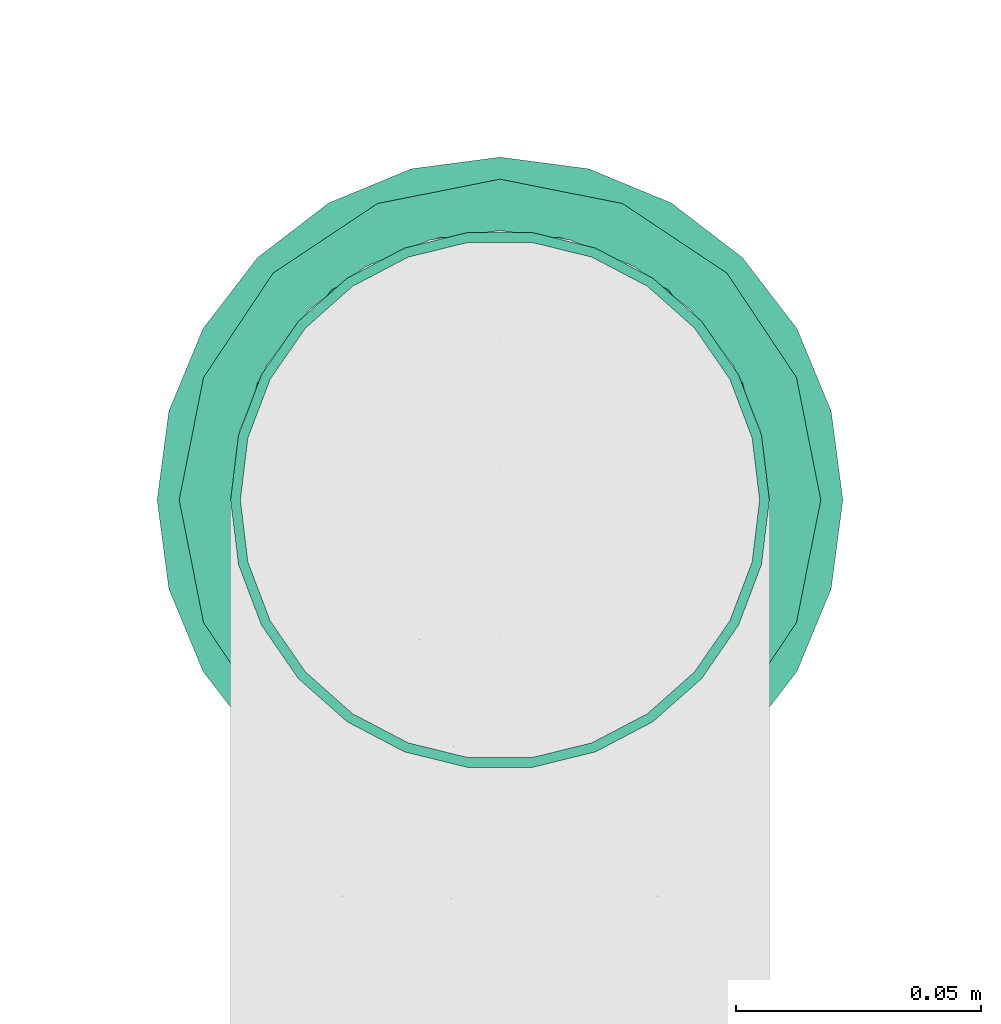
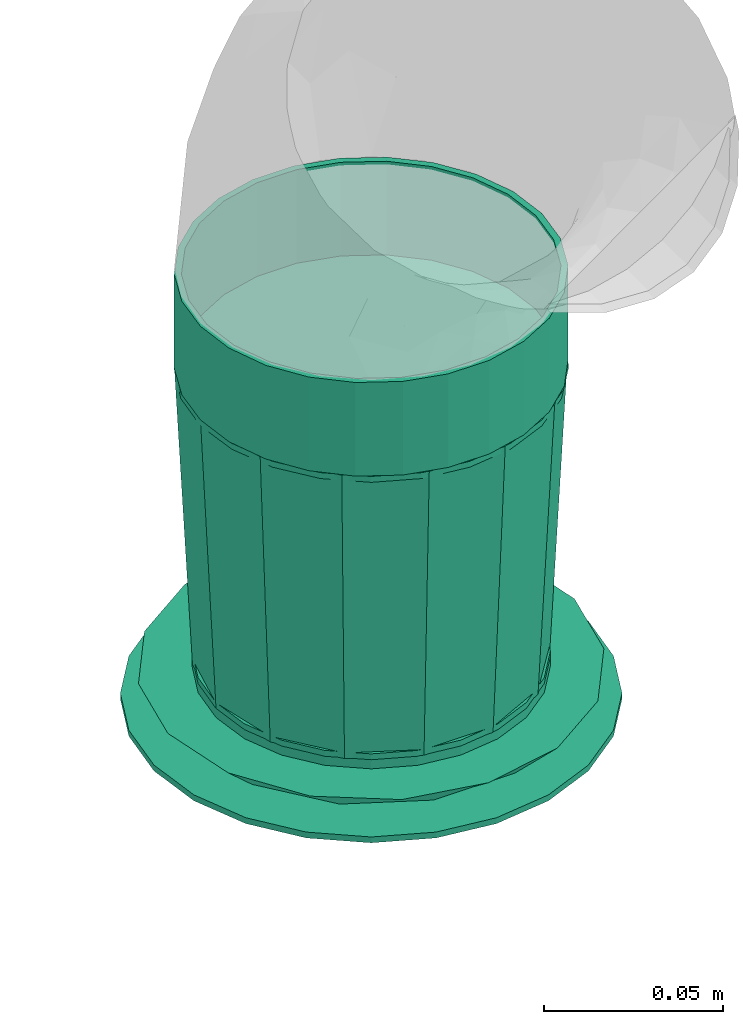
# One storey, part 42 of 123: 1 flow fitting, 1 flow segment, 1 flow terminal.
"""IFC2X3 building model written with IfcOpenShell, lengths in millimetres."""

import ifcopenshell
import ifcopenshell.guid

model = None  # the IFC model being written
_history = None  # IfcOwnerHistory: only IFC2X3 demands one
_inside = {}  # id of a spatial element -> (the spatial element, [elements in it])
_under = {}  # id of a project, library or spatial element -> (it, [spatial elements below it])
_declared = {}  # id of a project -> (the project, [libraries it declares])
_typed = {}  # id of a type object -> (the type object, [elements of that type])
_made_of = {}  # id of a material, layer set ... -> (it, [elements and type objects made of it])


def new_model(schema):
    """Start an empty IFC model of exactly this schema.

    Asked for "IFC4X3", IfcOpenShell would pick the latest addendum, in which some entities
    have other attributes; the version numbers below select the first issue.
    IFC2X3 requires an IfcOwnerHistory on every rooted entity: one is made here for all.
    """
    global model, _history
    if schema == "IFC4X3":
        model = ifcopenshell.file(schema_version=(4, 3, 0, 0))
    else:
        model = ifcopenshell.file(schema=schema)
    _inside.clear()
    _under.clear()
    _declared.clear()
    _typed.clear()
    _made_of.clear()
    _history = None
    if model.schema == "IFC2X3":
        org = make("IfcOrganization", Name="unknown")
        user = make(
            "IfcPersonAndOrganization",
            ThePerson=make("IfcPerson", FamilyName="unknown"),
            TheOrganization=org,
        )
        app = make(
            "IfcApplication",
            ApplicationDeveloper=org,
            Version="unknown",
            ApplicationFullName="unknown",
            ApplicationIdentifier="unknown",
        )
        _history = make(
            "IfcOwnerHistory",
            OwningUser=user,
            OwningApplication=app,
            ChangeAction="ADDED",
            CreationDate=0,
        )
    return model


def make(cls, **values):
    """One entity of the class cls with the attributes given. An attribute that is None is left unset."""
    return model.create_entity(
        cls, **{name: value for name, value in values.items() if value is not None}
    )


def entity(cls, *values):
    """Any entity or typed value of the class cls, its attributes in the order of the schema. None: left unset."""
    e = model.create_entity(cls)
    for i, value in enumerate(values):
        if value is not None:
            e[i] = value
    return e


def rooted(cls, **values):
    """An entity with a GlobalId (a new one), such as an element, a storey or a relation."""
    return make(cls, GlobalId=ifcopenshell.guid.new(), OwnerHistory=_history, **values)


def si_unit(unit_type, name, prefix=None):
    """IfcSIUnit, for example si_unit("LENGTHUNIT", "METRE", prefix="MILLI")."""
    return make("IfcSIUnit", UnitType=unit_type, Prefix=prefix, Name=name)


def converted_unit(unit_type, name, factor, base, dimensions=None, offset=None):
    """IfcConversionBasedUnit, such as the inch: factor (a typed value) times the base unit."""
    return make(
        "IfcConversionBasedUnit"
        if offset is None
        else "IfcConversionBasedUnitWithOffset",
        ConversionOffset=offset,
        Dimensions=None
        if dimensions is None
        else entity("IfcDimensionalExponents", *dimensions),
        UnitType=unit_type,
        Name=name,
        ConversionFactor=make(
            "IfcMeasureWithUnit", ValueComponent=factor, UnitComponent=base
        ),
    )


def derived_unit(unit_type, elements):
    """IfcDerivedUnit: a product of units, each with its exponent."""
    return make(
        "IfcDerivedUnit",
        Elements=[
            make("IfcDerivedUnitElement", Unit=unit, Exponent=power)
            for unit, power in elements
        ],
        UnitType=unit_type,
    )


def assignment(units):
    """IfcUnitAssignment: the units of a project."""
    return None if units is None else make("IfcUnitAssignment", Units=units)


def point(xyz):
    """IfcCartesianPoint."""
    return None if xyz is None else make("IfcCartesianPoint", Coordinates=xyz)


def direction(xyz):
    """IfcDirection."""
    return None if xyz is None else make("IfcDirection", DirectionRatios=xyz)


def frame(location, z_axis=None, x_axis=None):
    """IfcAxis2Placement3D, a coordinate frame: its origin and axes. An axis left out is left unset."""
    return make(
        "IfcAxis2Placement3D",
        Location=point(location),
        Axis=direction(z_axis),
        RefDirection=direction(x_axis),
    )


def frame_2d(location, x_axis=None):
    """IfcAxis2Placement2D, a coordinate frame in the plane: its origin and x axis."""
    return make(
        "IfcAxis2Placement2D", Location=point(location), RefDirection=direction(x_axis)
    )


def origin_with_axes():
    """The frame at (0, 0, 0) with the z axis (0, 0, 1) and the x axis (1, 0, 0) written out."""
    return frame((0.0, 0.0, 0.0), z_axis=(0.0, 0.0, 1.0), x_axis=(1.0, 0.0, 0.0))


def origin_2d_with_axis():
    """The frame at (0, 0) in the plane with the x axis (1, 0) written out."""
    return frame_2d((0.0, 0.0), x_axis=(1.0, 0.0))


def place(relative_to, where):
    """IfcLocalPlacement: puts the frame where relative to a parent placement (None: the world)."""
    return make(
        "IfcLocalPlacement", PlacementRelTo=relative_to, RelativePlacement=where
    )


def context(
    kind, dimensions, precision=None, world=None, true_north=None, identifier=None
):
    """IfcGeometricRepresentationContext, for example the 3D "Model" context."""
    return make(
        "IfcGeometricRepresentationContext",
        ContextIdentifier=identifier,
        ContextType=kind,
        CoordinateSpaceDimension=dimensions,
        Precision=precision,
        WorldCoordinateSystem=world,
        TrueNorth=true_north,
    )


def subcontext(parent, identifier, kind, view, scale=None):
    """IfcGeometricRepresentationSubContext, for example "Body" below "Model"."""
    return make(
        "IfcGeometricRepresentationSubContext",
        ContextIdentifier=identifier,
        ContextType=kind,
        ParentContext=parent,
        TargetScale=scale,
        TargetView=view,
    )


def project(units=None, contexts=None):
    """IfcProject with its units and contexts."""
    return rooted(
        "IfcProject",
        Name="project",
        RepresentationContexts=contexts,
        UnitsInContext=assignment(units),
    )


def spatial(cls, under=None, at=None, **own):
    """A site, building, storey or space (cls), placed at a placement, below another one or the project."""
    s = rooted(cls, ObjectPlacement=at, **own)
    if under is not None:
        _under.setdefault(under.id(), (under, []))[1].append(s)
    return s


def profile(cls, at=None, kind="AREA", **sizes):
    """A parametric profile (cls). Its sizes go by their IFC names, for example OverallWidth=200.0."""
    return make(cls, ProfileType=kind, Position=at, **sizes)


def hollow_circle(**sizes):
    """IfcCircleHollowProfileDef."""
    return profile("IfcCircleHollowProfileDef", **sizes)


def extrude(swept, where, along, depth):
    """IfcExtrudedAreaSolid: the profile swept, set in the frame where, extruded along a direction by depth."""
    return make(
        "IfcExtrudedAreaSolid",
        SweptArea=swept,
        Position=where,
        ExtrudedDirection=direction(along),
        Depth=depth,
    )


def faces_of(points, faces, orient=None, outer=None):
    """IfcFace entities. A face is a list of loops; a loop is a list of indices into points, from 0.

    orient and outer hold one flag for each loop. By default every Orientation is true, the
    first loop of a face is its IfcFaceOuterBound and the others are IfcFaceBound.
    """
    made = []
    for i, loops in enumerate(faces):
        bounds = []
        for j, loop in enumerate(loops):
            is_outer = j == 0 if outer is None else outer[i][j]
            bounds.append(
                make(
                    "IfcFaceOuterBound" if is_outer else "IfcFaceBound",
                    Bound=make("IfcPolyLoop", Polygon=[points[k] for k in loop]),
                    Orientation=True if orient is None else orient[i][j],
                )
            )
        made.append(make("IfcFace", Bounds=bounds))
    return made


def open_shell(faces, orient=None, outer=None):
    """The faces of one IfcOpenShell. surface_model builds it on its shared points."""
    return ("IfcOpenShell", faces, orient, outer)


def surface_model(cls, points, shells):
    """IfcFaceBasedSurfaceModel or IfcShellBasedSurfaceModel (cls): surfaces that need not close."""
    shared = [point(p) for p in points]
    made = [make(c, CfsFaces=faces_of(shared, fs, o, b)) for c, fs, o, b in shells]
    if cls == "IfcFaceBasedSurfaceModel":
        return make(cls, FbsmFaces=made)
    return make(cls, SbsmBoundary=made)


def shape(context_of_items, identifier, shape_type, items):
    """IfcShapeRepresentation: the items that make up one representation, for example the "Body"."""
    return make(
        "IfcShapeRepresentation",
        ContextOfItems=context_of_items,
        RepresentationIdentifier=identifier,
        RepresentationType=shape_type,
        Items=items,
    )


def source(mapping_origin, context_of_items, identifier, shape_type, items):
    """IfcRepresentationMap: a shape defined once, which mapped items show again and again."""
    return make(
        "IfcRepresentationMap",
        MappingOrigin=mapping_origin,
        MappedRepresentation=shape(context_of_items, identifier, shape_type, items),
    )


def transform(
    local_origin,
    x_axis=None,
    y_axis=None,
    z_axis=None,
    scale=None,
    scale2=None,
    scale3=None,
    uniform=True,
):
    """IfcCartesianTransformationOperator3D, or its non-uniform kind. x_axis, y_axis, z_axis: its Axis1, 2, 3."""
    if uniform:
        return make(
            "IfcCartesianTransformationOperator3D",
            Axis1=direction(x_axis),
            Axis2=direction(y_axis),
            LocalOrigin=point(local_origin),
            Scale=scale,
            Axis3=direction(z_axis),
        )
    return make(
        "IfcCartesianTransformationOperator3DnonUniform",
        Axis1=direction(x_axis),
        Axis2=direction(y_axis),
        LocalOrigin=point(local_origin),
        Scale=scale,
        Axis3=direction(z_axis),
        Scale2=scale2,
        Scale3=scale3,
    )


def mapped(mapping_source, mapping_target):
    """IfcMappedItem: shows the shape of a source again, moved by a transform."""
    return make(
        "IfcMappedItem", MappingSource=mapping_source, MappingTarget=mapping_target
    )


def material(Name=None, Category=None):
    """IfcMaterial."""
    return make("IfcMaterial", Name=Name, Category=Category)


def layer(
    of_material, thickness, ventilated=None, Name=None, Category=None, Priority=None
):
    """IfcMaterialLayer: one layer of a wall or slab, of a material (None: an air gap)."""
    return make(
        "IfcMaterialLayer",
        Material=of_material,
        LayerThickness=thickness,
        IsVentilated=ventilated,
        Name=Name,
        Category=Category,
        Priority=Priority,
    )


def layer_set(layers, Name=None):
    """IfcMaterialLayerSet."""
    return make("IfcMaterialLayerSet", MaterialLayers=layers, LayerSetName=Name)


def layer_usage(for_layer_set, set_direction, sense, offset, extent=None):
    """IfcMaterialLayerSetUsage: how a layer set lies in its element."""
    return make(
        "IfcMaterialLayerSetUsage",
        ForLayerSet=for_layer_set,
        LayerSetDirection=set_direction,
        DirectionSense=sense,
        OffsetFromReferenceLine=offset,
        ReferenceExtent=extent,
    )


def made_of(thing, what):
    """Note that an element or type object is made of a material, layer set ...; save() writes the relation."""
    if what is not None:
        _made_of.setdefault(what.id(), (what, []))[1].append(thing)
    return thing


def type_object(cls, material=None, **own):
    """A type object (cls), such as IfcWallType, which elements share."""
    return made_of(rooted(cls, **own), material)


def element(
    cls,
    number,
    at=None,
    inside=None,
    cuts=None,
    type_object=None,
    material=None,
    context=None,
    identifier="Body",
    shape_type=None,
    held_by="IfcProductDefinitionShape",
    body=None,
    shapes=None,
    **own,
):
    """One element of the class cls, such as IfcWall. Its Tag is "e" and its number.

    at: its placement. inside: the storey or other place that contains it. cuts: it is an
    opening in that element (IfcRelVoidsElement). A single representation is given by context,
    identifier, shape_type and body (its items); several are given by shapes. held_by: the class
    of the entity that holds the representations. save() writes the other relations.
    """
    e = rooted(cls, Tag="e%d" % number, ObjectPlacement=at, **own)
    if body is not None:
        shapes = [shape(context, identifier, shape_type, body)]
    if shapes is not None:
        e.Representation = make(held_by, Representations=shapes)
    if inside is not None:
        _inside.setdefault(inside.id(), (inside, []))[1].append(e)
    if cuts is not None:
        rooted(
            "IfcRelVoidsElement", RelatingBuildingElement=cuts, RelatedOpeningElement=e
        )
    if type_object is not None:
        _typed.setdefault(type_object.id(), (type_object, []))[1].append(e)
    return made_of(e, material)


def aggregate(whole, parts):
    """IfcRelAggregates: a whole, such as a stair, and the parts it consists of."""
    return rooted("IfcRelAggregates", RelatingObject=whole, RelatedObjects=parts)


def save(model, path):
    """Write the relations noted so far, then the file.

    IfcRelAggregates (storeys below a building ...), IfcRelContainedInSpatialStructure (elements
    in a storey), IfcRelDefinesByType, IfcRelAssociatesMaterial and IfcRelDeclares: one each for
    every whole, place, type object, material and project.
    """
    for whole, parts in _under.values():
        aggregate(whole, parts)
    for where, things in _inside.values():
        rooted(
            "IfcRelContainedInSpatialStructure",
            RelatedElements=things,
            RelatingStructure=where,
        )
    for kind, things in _typed.values():
        rooted("IfcRelDefinesByType", RelatedObjects=things, RelatingType=kind)
    for what, things in _made_of.values():
        rooted("IfcRelAssociatesMaterial", RelatedObjects=things, RelatingMaterial=what)
    for by, libraries in _declared.values():
        rooted("IfcRelDeclares", RelatingContext=by, RelatedDefinitions=libraries)
    model.write(path)


model = new_model("IFC2X3")

# Units and contexts
model_context = context("Model", 3, precision=1e-05, world=origin_with_axes(), true_north=direction((0.0, 1.0)))
body_context = subcontext(model_context, "Body", "Model", "MODEL_VIEW")
ifc_project = project(units=[si_unit("AREAUNIT", "SQUARE_METRE"), si_unit("VOLUMEUNIT", "CUBIC_METRE", prefix="DECI"), si_unit("TIMEUNIT", "SECOND"), si_unit("THERMODYNAMICTEMPERATUREUNIT", "DEGREE_CELSIUS"), si_unit("PRESSUREUNIT", "PASCAL"), si_unit("MASSUNIT", "GRAM", prefix="KILO"), si_unit("LENGTHUNIT", "METRE", prefix="MILLI"), si_unit("POWERUNIT", "WATT"), si_unit("ELECTRICCURRENTUNIT", "AMPERE"), si_unit("ELECTRICVOLTAGEUNIT", "VOLT"), derived_unit("VOLUMETRICFLOWRATEUNIT", [(si_unit("VOLUMEUNIT", "CUBIC_METRE", prefix="DECI"), 1), (si_unit("TIMEUNIT", "SECOND"), -1)]), derived_unit("LINEARVELOCITYUNIT", [(si_unit("LENGTHUNIT", "METRE"), 1), (si_unit("TIMEUNIT", "SECOND"), -1)]), derived_unit("MASSDENSITYUNIT", [(si_unit("MASSUNIT", "GRAM", prefix="KILO"), 1), (si_unit("VOLUMEUNIT", "CUBIC_METRE"), -1)]), converted_unit("PLANEANGLEUNIT", "DEGREE", entity("IfcRatioMeasure", 0.01745), si_unit("PLANEANGLEUNIT", "RADIAN"), dimensions=[0, 0, 0, 0, 0, 0, 0])], contexts=[model_context])

# Site, building, storey
site_placement = place(None, origin_with_axes())
site = spatial("IfcSite", under=ifc_project, at=site_placement, CompositionType="ELEMENT")
building_placement = place(site_placement, origin_with_axes())
building = spatial("IfcBuilding", under=site, at=building_placement, Name="mc-building", CompositionType="ELEMENT")
storey_placement = place(building_placement, origin_with_axes())
storey = spatial("IfcBuildingStorey", under=building, at=storey_placement, Name="1. Korrus", CompositionType="ELEMENT", Elevation=0.0)

# Flow terminal
air_terminal_type = type_object("IfcAirTerminalType", Name="100", PredefinedType="NOTDEFINED")
shared_shape_1 = source(origin_with_axes(), body_context, "Body", "SurfaceModel", [
    surface_model("IfcShellBasedSurfaceModel", [(11.2, -70.0, 0.0), (11.2, -67.61481, -18.11733), (11.2, -67.61481, 18.11733), (6.2, -14.64625, -20.15883), (9.2, -22.36867, -22.36867), (6.2, -21.19625, -15.39997), (9.2, 16.375, -28.36233), (6.2, 8.09625, -24.91768), (6.2, 14.64625, -20.15883), (6.2, -8.09625, -24.91768), (9.2, -16.375, -28.36233), (6.2, 21.19625, -15.39997), (9.2, 22.36867, -22.36867), (9.2, -8.1875, -30.55617), (9.2, 8.1875, -30.55617), (9.2, 28.36233, -16.375), (9.2, -28.36233, -16.375), (6.2, 14.64625, 20.15883), (9.2, 22.36867, 22.36867), (6.2, 21.19625, 15.39997), (9.2, -16.375, 28.36233), (6.2, -8.09625, 24.91768), (6.2, -14.64625, 20.15883), (6.2, 8.09625, 24.91768), (9.2, 16.375, 28.36233), (6.2, -21.19625, 15.39997), (9.2, -22.36867, 22.36867), (9.2, 8.1875, 30.55617), (9.2, -8.1875, 30.55617), (9.2, -28.36233, 16.375), (9.2, 28.36233, 16.375), (6.2, -53.11211, -25.57744), (6.2, -36.75472, -46.08897), (6.2, -13.11761, -57.472), (6.2, 13.11761, -57.472), (6.2, 36.75472, -46.08897), (6.2, 53.11211, -25.57744), (0.0, -12.53288, -63.00706), (6.2, 0.0, -57.472), (0.0, -46.3155, -46.3155), (0.0, -35.69063, -53.4148), (0.0, 0.0, -65.5), (6.2, 44.93342, -35.83321), (0.0, 46.3155, -46.3155), (0.0, 35.69063, -53.4148), (6.2, -44.93342, -35.83321), (0.0, 12.53288, -63.00706), (0.0, 25.06576, -60.51411), (6.2, 56.03105, -12.78872), (0.0, 60.51411, -25.06576), (0.0, 63.00706, -12.53288), (0.0, 53.4148, -35.69063), (0.0, -25.06576, -60.51411), (0.0, -63.00706, -12.53288), (0.0, -60.51411, -25.06576), (6.2, -56.03105, -12.78872), (0.0, -53.4148, -35.69063), (6.2, 13.11761, 57.472), (0.0, 12.53288, 63.00706), (6.2, 0.0, 57.472), (6.2, 36.75472, 46.08897), (0.0, 46.3155, 46.3155), (0.0, 35.69063, 53.4148), (0.0, 0.0, 65.5), (6.2, -44.93342, 35.83321), (6.2, -36.75472, 46.08897), (0.0, -46.3155, 46.3155), (0.0, -35.69063, 53.4148), (6.2, 44.93342, 35.83321), (0.0, -12.53288, 63.00706), (0.0, -25.06576, 60.51411), (6.2, -13.11761, 57.472), (6.2, -56.03105, 12.78872), (0.0, -60.51411, 25.06576), (0.0, -63.00706, 12.53288), (0.0, -53.4148, 35.69063), (0.0, 25.06576, 60.51411), (0.0, 63.00706, 12.53288), (0.0, 60.51411, 25.06576), (6.2, 56.03105, 12.78872), (0.0, 53.4148, 35.69063), (-3.1, 43.30127, 25.0), (-3.1, -48.29629, -12.94095), (-3.1, -43.30127, 25.0), (-3.1, 25.0, -43.30127), (-3.1, 48.29629, -12.94095), (-3.1, 35.35534, -35.35534), (-3.1, -35.35534, -35.35534), (-3.1, -25.0, -43.30127), (-43.1, 43.46666, 11.64686), (-3.1, 38.97115, 22.5), (-3.1, 43.46666, 11.64686), (-3.1, 45.0, 0.0), (-43.1, 45.0, 0.0), (-3.1, 31.81981, 31.81981), (-43.1, 38.97115, 22.5), (-43.1, -38.97115, 22.5), (-3.1, -38.97115, 22.5), (-3.1, -31.81981, 31.81981), (-3.1, -43.46666, 11.64686), (-43.1, -43.46666, 11.64686), (-43.1, -45.0, 0.0), (-3.1, -45.0, 0.0), (-43.1, -43.46666, -11.64686), (-3.1, -38.97115, -22.5), (-3.1, -43.46666, -11.64686), (-3.1, -11.64686, -43.46666), (-3.1, -22.5, -38.97115), (-43.1, -22.5, -38.97115), (-3.1, -31.81981, -31.81981), (-43.1, -38.97115, -22.5), (-43.1, 22.5, -38.97115), (-3.1, 22.5, -38.97115), (-3.1, 11.64686, -43.46666), (-43.1, 38.97115, -22.5), (-3.1, 38.97115, -22.5), (-3.1, 31.81981, -31.81981), (-3.1, 43.46666, -11.64686), (-43.1, 43.46666, -11.64686), (11.2, -49.49747, -49.49747), (11.2, -35.0, -60.62178), (11.2, -18.11733, -67.61481), (11.2, 67.61481, 18.11733), (11.2, -60.62178, -35.0), (11.2, 18.11733, -67.61481), (11.2, 35.0, -60.62178), (11.2, 0.0, -70.0), (11.2, 60.62178, -35.0), (11.2, 67.61481, -18.11733), (11.2, 49.49747, -49.49747), (11.2, -49.49747, 49.49747), (11.2, -60.62178, 35.0), (11.2, -35.0, 60.62178), (11.2, -18.11733, 67.61481), (11.2, 0.0, 70.0), (11.2, 60.62178, 35.0), (11.2, 49.49747, 49.49747), (11.2, 70.0, 0.0), (11.2, 35.0, 60.62178), (11.2, 18.11733, 67.61481), (9.2, -49.49747, 49.49747), (9.2, -35.0, 60.62178), (9.2, -18.11733, 67.61481), (9.2, -67.61481, 18.11733), (9.2, -70.0, 0.0), (9.2, -60.62178, 35.0), (9.2, 67.61481, 18.11733), (9.2, 35.0, 60.62178), (9.2, 18.11733, 67.61481), (9.2, 0.0, 70.0), (9.2, 60.62178, 35.0), (9.2, 49.49747, 49.49747), (9.2, -67.61481, -18.11733), (9.2, -49.49747, -49.49747), (9.2, -60.62178, -35.0), (9.2, -18.11733, -67.61481), (9.2, 70.0, 0.0), (9.2, -35.0, -60.62178), (9.2, 0.0, -70.0), (9.2, 60.62178, -35.0), (9.2, 49.49747, -49.49747), (9.2, 67.61481, -18.11733), (9.2, 35.0, -60.62178), (9.2, 18.11733, -67.61481), (9.2, -32.75, 0.0), (9.2, 0.0, 32.75), (9.2, 32.75, 0.0), (9.2, 0.0, -32.75), (6.2, 26.2, 0.0), (6.2, -26.2, 0.0), (9.2, -31.06579, -6.28555), (6.2, -23.69812, -7.69999), (6.2, 23.69812, -7.69999), (9.2, 31.06579, -6.28555), (6.2, 0.0, -24.91768), (9.2, 31.06579, 6.28555), (6.2, 23.69812, 7.69999), (6.2, -23.69812, 7.69999), (9.2, -31.06579, 6.28555), (6.2, 0.0, 24.91768), (6.2, 53.11211, 25.57744), (6.2, 58.95, 0.0), (6.2, -53.11211, 25.57744), (6.2, -58.95, 0.0), (0.0, 65.5, 0.0), (0.0, -65.5, 0.0), (6.2, -24.93616, -51.78048), (6.2, 24.93616, -51.78048), (6.2, 24.93616, 51.78048), (6.2, -24.93616, 51.78048), (-3.1, 0.0, 50.0), (-3.1, 35.35534, 35.35534), (-3.1, -12.94095, 48.29629), (-3.1, -25.0, 43.30127), (-3.1, -35.35534, 35.35534), (-3.1, 25.0, 43.30127), (-3.1, 12.94095, 48.29629), (-3.1, 48.29629, 12.94095), (-3.1, 50.0, 0.0), (-3.1, -50.0, 0.0), (-3.1, -48.29629, 12.94095), (-3.1, -43.30127, -25.0), (-3.1, -12.94095, -48.29629), (-3.1, 0.0, -50.0), (-3.1, 43.30127, -25.0), (-3.1, 12.94095, -48.29629), (0.0, -12.94095, -48.29629), (0.0, 0.0, -50.0), (0.0, -25.0, -43.30127), (0.0, -35.35534, -35.35534), (0.0, -48.29629, -12.94095), (0.0, 25.0, -43.30127), (0.0, -43.30127, -25.0), (0.0, 43.30127, 25.0), (0.0, 12.94095, -48.29629), (0.0, 43.30127, -25.0), (0.0, 48.29629, -12.94095), (0.0, 35.35534, -35.35534), (0.0, 50.0, 0.0), (0.0, -50.0, 0.0), (0.0, -48.29629, 12.94095), (0.0, -43.30127, 25.0), (0.0, -35.35534, 35.35534), (0.0, -12.94095, 48.29629), (0.0, -25.0, 43.30127), (0.0, 35.35534, 35.35534), (0.0, 0.0, 50.0), (0.0, 48.29629, 12.94095), (0.0, 25.0, 43.30127), (0.0, 12.94095, 48.29629), (-43.1, -22.5, 38.97115), (-43.1, -11.64686, 43.46666), (-43.1, 0.0, 45.0), (-43.1, 11.64686, 43.46666), (-43.1, -31.81981, 31.81981), (-43.1, 31.81981, 31.81981), (-43.1, 22.5, 38.97115), (-43.1, -31.81981, -31.81981), (-43.1, 31.81981, -31.81981), (-43.1, -11.64686, -43.46666), (-43.1, 11.64686, -43.46666), (-43.1, 0.0, -45.0), (-3.1, 0.0, -45.0), (-3.1, 0.0, 45.0), (-3.1, -22.5, 38.97115), (-3.1, -11.64686, 43.46666), (-3.1, 11.64686, 43.46666), (-3.1, 22.5, 38.97115)], [open_shell([[[0, 1, 2]], [[3, 4, 5]], [[6, 7, 8]], [[3, 9, 10]], [[4, 3, 10]], [[11, 12, 8]], [[13, 10, 9]], [[7, 6, 14]], [[6, 8, 12]], [[12, 11, 15]], [[16, 5, 4]], [[17, 18, 19]], [[20, 21, 22]], [[17, 23, 24]], [[18, 17, 24]], [[25, 26, 22]], [[27, 24, 23]], [[21, 20, 28]], [[20, 22, 26]], [[26, 25, 29]], [[30, 19, 18]], [[31, 32, 33]], [[34, 35, 36]], [[33, 37, 38]], [[32, 39, 40]], [[41, 38, 37]], [[42, 35, 43]], [[44, 43, 35]], [[39, 32, 45]], [[46, 47, 34]], [[48, 49, 50]], [[38, 46, 34]], [[42, 43, 51]], [[33, 52, 37]], [[53, 54, 55]], [[46, 38, 41]], [[56, 39, 45]], [[57, 58, 59]], [[60, 61, 62]], [[63, 59, 58]], [[64, 65, 66]], [[67, 66, 65]], [[61, 60, 68]], [[69, 70, 71]], [[72, 73, 74]], [[59, 69, 71]], [[64, 66, 75]], [[57, 76, 58]], [[77, 78, 79]], [[69, 59, 63]], [[80, 61, 68]], [[81, 82, 83]], [[84, 85, 86]], [[87, 82, 88]], [[89, 90, 91]], [[91, 92, 93]], [[94, 90, 95]], [[96, 97, 98]], [[99, 97, 100]], [[101, 102, 99]], [[103, 104, 105]], [[105, 102, 101]], [[106, 107, 108]], [[109, 104, 110]], [[111, 112, 113]], [[114, 115, 116]], [[117, 115, 118]], [[93, 92, 117]], [[119, 120, 121]], [[1, 119, 121]], [[122, 1, 121]], [[123, 119, 1]], [[124, 122, 121]], [[125, 122, 124]], [[121, 126, 124]], [[127, 128, 129]], [[129, 128, 122]], [[129, 122, 125]], [[130, 131, 2]], [[132, 130, 2]], [[122, 133, 2]], [[132, 2, 133]], [[134, 133, 122]], [[135, 136, 122]], [[122, 128, 137]], [[136, 138, 122]], [[139, 122, 138]], [[122, 139, 134]], [[2, 1, 122]], [[140, 141, 142]], [[143, 140, 142]], [[142, 144, 143]], [[145, 140, 143]], [[146, 144, 142]], [[147, 146, 148]], [[149, 148, 146]], [[150, 146, 151]], [[147, 151, 146]], [[146, 142, 149]], [[146, 152, 144]], [[153, 154, 152]], [[155, 153, 152]], [[146, 156, 155]], [[157, 153, 155]], [[158, 155, 156]], [[159, 160, 161]], [[156, 161, 160]], [[160, 162, 156]], [[163, 156, 162]], [[163, 158, 156]], [[152, 146, 155]], [[156, 128, 161]], [[161, 127, 159]], [[162, 160, 125]], [[129, 160, 159]], [[163, 162, 124]], [[128, 127, 161]], [[156, 137, 128]], [[162, 125, 124]], [[125, 160, 129]], [[159, 127, 129]], [[163, 124, 126]], [[126, 158, 163]], [[158, 121, 155]], [[155, 120, 157]], [[154, 153, 123]], [[119, 153, 157]], [[152, 154, 1]], [[120, 119, 157]], [[155, 121, 120]], [[152, 1, 0]], [[1, 154, 123]], [[153, 119, 123]], [[152, 0, 144]], [[126, 121, 158]], [[144, 2, 143]], [[143, 131, 145]], [[141, 140, 132]], [[130, 140, 145]], [[142, 141, 133]], [[2, 131, 143]], [[144, 0, 2]], [[141, 132, 133]], [[132, 140, 130]], [[145, 131, 130]], [[142, 133, 134]], [[134, 149, 142]], [[149, 139, 148]], [[148, 138, 147]], [[150, 151, 135]], [[136, 151, 147]], [[146, 150, 122]], [[138, 136, 147]], [[148, 139, 138]], [[146, 122, 137]], [[122, 150, 135]], [[151, 136, 135]], [[146, 137, 156]], [[134, 139, 149]], [[30, 24, 164]], [[24, 20, 164]], [[165, 20, 24]], [[164, 20, 29]], [[166, 30, 16]], [[16, 6, 166]], [[167, 6, 10]], [[30, 164, 16]], [[10, 6, 16]], [[6, 15, 166]], [[21, 19, 11]], [[23, 19, 21]], [[11, 19, 168]], [[7, 25, 21]], [[7, 5, 169]], [[21, 11, 7]], [[9, 5, 7]], [[169, 25, 7]], [[170, 164, 169]], [[170, 171, 16]], [[11, 172, 15]], [[172, 168, 173]], [[174, 13, 9]], [[166, 173, 168]], [[172, 173, 15]], [[169, 171, 170]], [[5, 16, 171]], [[167, 174, 14]], [[174, 167, 13]], [[14, 174, 7]], [[175, 166, 168]], [[175, 176, 30]], [[25, 177, 29]], [[177, 169, 178]], [[179, 27, 23]], [[164, 178, 169]], [[177, 178, 29]], [[168, 176, 175]], [[19, 30, 176]], [[165, 179, 28]], [[179, 165, 27]], [[28, 179, 21]], [[180, 60, 57]], [[181, 180, 65]], [[65, 57, 71]], [[180, 57, 65]], [[65, 182, 181]], [[182, 36, 181]], [[183, 34, 36]], [[31, 34, 183]], [[31, 33, 34]], [[182, 183, 36]], [[70, 63, 49]], [[70, 73, 66]], [[49, 63, 184]], [[78, 76, 61]], [[76, 78, 184]], [[184, 63, 76]], [[73, 70, 49]], [[39, 54, 185]], [[41, 39, 185]], [[52, 39, 41]], [[43, 185, 49]], [[185, 43, 47]], [[185, 47, 41]], [[73, 49, 185]], [[55, 54, 31]], [[31, 54, 56]], [[52, 186, 40]], [[53, 55, 183]], [[56, 45, 31]], [[185, 53, 183]], [[32, 40, 186]], [[33, 186, 52]], [[44, 35, 187]], [[49, 36, 51]], [[34, 47, 187]], [[42, 51, 36]], [[187, 47, 44]], [[49, 48, 36]], [[48, 50, 181]], [[184, 181, 50]], [[79, 78, 180]], [[180, 78, 80]], [[76, 188, 62]], [[77, 79, 181]], [[80, 68, 180]], [[184, 77, 181]], [[60, 62, 188]], [[57, 188, 76]], [[67, 65, 189]], [[73, 182, 75]], [[71, 70, 189]], [[64, 75, 182]], [[189, 70, 67]], [[73, 72, 182]], [[72, 74, 183]], [[185, 183, 74]], [[190, 191, 192]], [[193, 192, 194]], [[83, 192, 81]], [[194, 192, 83]], [[195, 191, 196]], [[191, 190, 196]], [[197, 198, 81]], [[81, 192, 191]], [[198, 84, 81]], [[199, 200, 83]], [[81, 88, 82]], [[201, 82, 87]], [[88, 81, 202]], [[81, 203, 202]], [[204, 86, 85]], [[205, 203, 84]], [[84, 198, 85]], [[81, 84, 203]], [[199, 83, 82]], [[206, 207, 208]], [[209, 208, 210]], [[210, 208, 211]], [[212, 209, 210]], [[210, 211, 213]], [[214, 211, 207]], [[211, 208, 207]], [[215, 216, 217]], [[211, 217, 216]], [[216, 218, 211]], [[219, 210, 220]], [[221, 210, 213]], [[222, 221, 223]], [[213, 223, 221]], [[224, 222, 223]], [[223, 225, 226]], [[227, 213, 218]], [[218, 213, 211]], [[228, 229, 225]], [[223, 213, 225]], [[226, 225, 229]], [[221, 220, 210]], [[199, 220, 200]], [[200, 221, 83]], [[193, 194, 224]], [[222, 194, 83]], [[192, 193, 223]], [[220, 221, 200]], [[199, 219, 220]], [[193, 224, 223]], [[224, 194, 222]], [[83, 221, 222]], [[192, 223, 226]], [[226, 190, 192]], [[190, 229, 196]], [[196, 228, 195]], [[81, 191, 213]], [[225, 191, 195]], [[197, 81, 227]], [[228, 225, 195]], [[196, 229, 228]], [[197, 227, 218]], [[227, 81, 213]], [[191, 225, 213]], [[197, 218, 198]], [[226, 229, 190]], [[198, 216, 85]], [[85, 215, 204]], [[84, 86, 211]], [[217, 86, 204]], [[205, 84, 214]], [[216, 215, 85]], [[198, 218, 216]], [[84, 211, 214]], [[211, 86, 217]], [[204, 215, 217]], [[205, 214, 207]], [[207, 203, 205]], [[203, 206, 202]], [[202, 208, 88]], [[201, 87, 212]], [[209, 87, 88]], [[82, 201, 210]], [[208, 209, 88]], [[202, 206, 208]], [[82, 210, 219]], [[210, 201, 212]], [[87, 209, 212]], [[82, 219, 199]], [[207, 206, 203]], [[230, 231, 232]], [[230, 232, 233]], [[230, 100, 96]], [[234, 230, 96]], [[100, 230, 233]], [[235, 89, 236]], [[100, 233, 236]], [[95, 89, 235]], [[118, 89, 93]], [[118, 236, 89]], [[118, 100, 236]], [[110, 103, 101]], [[237, 110, 101]], [[238, 108, 101]], [[237, 101, 108]], [[239, 108, 238]], [[114, 238, 118]], [[238, 101, 118]], [[240, 241, 111]], [[238, 111, 241]], [[238, 241, 239]], [[100, 118, 101]], [[106, 242, 107]], [[107, 112, 109]], [[102, 105, 104]], [[112, 104, 109]], [[92, 104, 117]], [[113, 112, 242]], [[112, 107, 242]], [[115, 117, 116]], [[112, 116, 117]], [[112, 117, 104]], [[92, 102, 104]], [[97, 99, 243]], [[98, 97, 244]], [[243, 245, 244]], [[97, 243, 244]], [[246, 243, 99]], [[90, 94, 91]], [[92, 91, 247]], [[94, 247, 91]], [[247, 99, 92]], [[247, 246, 99]], [[102, 92, 99]], [[101, 99, 100]], [[100, 97, 96]], [[230, 234, 244]], [[98, 234, 96]], [[231, 230, 245]], [[245, 230, 244]], [[244, 234, 98]], [[245, 243, 231]], [[243, 232, 231]], [[236, 233, 246]], [[236, 247, 235]], [[89, 95, 90]], [[94, 95, 235]], [[93, 89, 91]], [[232, 246, 233]], [[246, 247, 236]], [[243, 246, 232]], [[247, 94, 235]], [[93, 117, 118]], [[118, 115, 114]], [[111, 238, 112]], [[116, 238, 114]], [[240, 111, 113]], [[112, 238, 116]], [[240, 113, 242]], [[242, 241, 240]], [[108, 239, 106]], [[108, 107, 237]], [[103, 110, 104]], [[109, 110, 237]], [[101, 103, 105]], [[241, 106, 239]], [[242, 106, 241]], [[107, 109, 237]]])]),
])
flow_terminal_placement = place(storey_placement, frame((15517.82156, 4715.81442, 2200.0), z_axis=(0.0, -1.0, 0.0), x_axis=(0.0, 0.0, -1.0)))
element("IfcFlowTerminal", 1, at=flow_terminal_placement, inside=storey, type_object=air_terminal_type, Name="100", context=body_context, shape_type="MappedRepresentation", body=[
    mapped(shared_shape_1, transform((0.0, 0.0, 0.0), scale=1.0)),
])

# Flow fitting
duct_fitting_type = type_object("IfcDuctFittingType", PredefinedType="TRANSITION")
shared_shape_2 = source(origin_with_axes(), body_context, "Body", "SurfaceModel", [
    surface_model("IfcShellBasedSurfaceModel", [(100.0, -55.0, 0.0), (100.0, -12.23865, 53.62104), (100.0, -34.29194, 43.00073), (100.0, 49.55329, 23.86361), (100.0, 34.29194, 43.00073), (100.0, 49.55329, -23.86361), (0.0, -45.04844, -21.69419), (0.0, -50.0, 0.0), (0.0, -45.04844, 21.69419), (0.0, 31.17449, 39.09157), (0.0, 45.04844, 21.69419), (0.0, 50.0, 0.0), (98.0, 47.63139, 27.5), (98.0, 0.0, 55.0), (98.0, 38.89087, 38.89087), (98.0, -38.89087, 38.89087), (98.0, -47.63139, 27.5), (100.0, 12.23865, 53.62104), (100.0, -49.55329, 23.86361), (100.0, 55.0, 0.0), (100.0, 12.23865, -53.62104), (100.0, 34.29194, -43.00073), (100.0, -49.55329, -23.86361), (100.0, -34.29194, -43.00073), (100.0, -12.23865, -53.62104), (0.0, -31.17449, 39.09157), (0.0, -11.12605, 48.7464), (0.0, 11.12605, 48.7464), (0.0, -31.17449, -39.09157), (0.0, 11.12605, -48.7464), (0.0, -11.12605, -48.7464), (0.0, 45.04844, -21.69419), (0.0, 31.17449, -39.09157), (0.0, 47.52422, -10.84709), (0.0, 38.11147, -30.39288), (100.0, 41.92261, -33.43217), (100.0, -41.92261, -33.43217), (0.0, -38.11147, -30.39288), (100.0, 23.2653, -48.31088), (0.0, 21.15027, -43.91899), (100.0, 52.32388, -11.72483), (0.0, 0.0, -48.7464), (100.0, 0.0, -53.62104), (0.0, -21.15027, -43.91899), (100.0, -23.2653, -48.31088), (0.0, -47.52422, -10.84709), (100.0, -52.32388, -11.72483), (0.0, -47.52422, 10.84709), (0.0, -38.11147, 30.39288), (100.0, -41.92261, 33.43217), (100.0, 41.92261, 33.43217), (0.0, 38.11147, 30.39288), (100.0, -23.2653, 48.31088), (0.0, -21.15027, 43.91899), (100.0, -52.32388, 11.72483), (0.0, 0.0, 48.7464), (100.0, 0.0, 53.62104), (0.0, 21.15027, 43.91899), (100.0, 23.2653, 48.31088), (0.0, 47.52422, 10.84709), (100.0, 52.32388, 11.72483), (100.0, -14.23505, -53.12592), (100.0, 0.0, -55.0), (100.0, -27.5, -47.63139), (100.0, 27.5, -47.63139), (100.0, -38.89087, -38.89087), (100.0, -53.12592, -14.23505), (100.0, -47.63139, -27.5), (100.0, -47.63139, 27.5), (100.0, 14.23505, -53.12592), (100.0, 38.89087, -38.89087), (100.0, 47.63139, -27.5), (100.0, 47.63139, 27.5), (100.0, 53.12592, -14.23505), (100.0, -53.12592, 14.23505), (100.0, -38.89087, 38.89087), (100.0, -27.5, 47.63139), (100.0, 0.0, 55.0), (100.0, -14.23505, 53.12592), (100.0, 53.12592, 14.23505), (100.0, 38.89087, 38.89087), (100.0, 27.5, 47.63139), (100.0, 14.23505, 53.12592), (98.0, -27.5, 47.63139), (98.0, -14.23505, 53.12592), (98.0, -53.12592, -14.23505), (98.0, 14.23505, 53.12592), (98.0, 27.5, 47.63139), (98.0, 53.12592, 14.23505), (98.0, 55.0, 0.0), (98.0, -47.63139, -27.5), (98.0, -53.12592, 14.23505), (98.0, 27.5, -47.63139), (98.0, -27.5, -47.63139), (98.0, -38.89087, -38.89087), (98.0, 0.0, -55.0), (98.0, -14.23505, -53.12592), (98.0, 38.89087, -38.89087), (98.0, 47.63139, -27.5), (98.0, 53.12592, -14.23505), (98.0, 14.23505, -53.12592), (98.0, -55.0, 0.0), (0.0, 0.0, 50.0), (0.0, 35.35534, 35.35534), (0.0, -12.94095, 48.29629), (0.0, -25.0, 43.30127), (0.0, -35.35534, 35.35534), (0.0, -48.29629, 12.94095), (0.0, -43.30127, 25.0), (0.0, 25.0, 43.30127), (0.0, 12.94095, 48.29629), (0.0, 43.30127, 25.0), (0.0, 48.29629, 12.94095), (0.0, 25.0, -43.30127), (0.0, 48.29629, -12.94095), (0.0, -48.29629, -12.94095), (0.0, -43.30127, -25.0), (0.0, -12.94095, -48.29629), (0.0, -25.0, -43.30127), (0.0, -35.35534, -35.35534), (0.0, 43.30127, -25.0), (0.0, 35.35534, -35.35534), (0.0, 12.94095, -48.29629), (0.0, 0.0, -50.0), (2.0, -35.35534, -35.35534), (2.0, -25.0, -43.30127), (2.0, -12.94095, -48.29629), (2.0, -43.30127, -25.0), (2.0, 0.0, -50.0), (2.0, -48.29629, -12.94095), (2.0, -50.0, 0.0), (2.0, 12.94095, -48.29629), (2.0, 25.0, -43.30127), (2.0, 43.30127, -25.0), (2.0, 48.29629, -12.94095), (2.0, 35.35534, -35.35534), (2.0, -48.29629, 12.94095), (2.0, -35.35534, 35.35534), (2.0, -43.30127, 25.0), (2.0, 35.35534, 35.35534), (2.0, -12.94095, 48.29629), (2.0, -25.0, 43.30127), (2.0, 0.0, 50.0), (2.0, 43.30127, 25.0), (2.0, 48.29629, 12.94095), (2.0, 50.0, 0.0), (2.0, 25.0, 43.30127), (2.0, 12.94095, 48.29629)], [open_shell([[[0, 1, 2]], [[3, 4, 5]], [[6, 7, 8]], [[9, 10, 11]], [[12, 13, 14]], [[15, 13, 16]], [[0, 4, 17]], [[2, 18, 0]], [[1, 0, 17]], [[3, 5, 19]], [[20, 21, 5]], [[22, 20, 5]], [[22, 5, 0]], [[22, 23, 24]], [[22, 24, 20]], [[4, 0, 5]], [[8, 25, 6]], [[6, 25, 26]], [[6, 26, 27]], [[11, 27, 9]], [[28, 6, 29]], [[30, 28, 29]], [[31, 6, 11]], [[31, 32, 29]], [[31, 29, 6]], [[27, 11, 6]], [[31, 33, 5]], [[34, 35, 32]], [[36, 22, 6]], [[36, 37, 23]], [[38, 29, 39]], [[33, 40, 5]], [[33, 11, 40]], [[19, 40, 11]], [[32, 21, 39]], [[32, 35, 21]], [[34, 31, 35]], [[30, 41, 42]], [[28, 43, 44]], [[42, 41, 20]], [[7, 45, 46]], [[38, 39, 21]], [[46, 0, 7]], [[6, 37, 36]], [[38, 20, 29]], [[43, 30, 24]], [[42, 24, 30]], [[28, 23, 37]], [[6, 22, 45]], [[35, 31, 5]], [[44, 43, 24]], [[20, 41, 29]], [[46, 45, 22]], [[44, 23, 28]], [[8, 47, 18]], [[48, 49, 25]], [[50, 3, 10]], [[50, 51, 4]], [[52, 26, 53]], [[47, 54, 18]], [[47, 7, 54]], [[0, 54, 7]], [[25, 2, 53]], [[25, 49, 2]], [[48, 8, 49]], [[27, 55, 56]], [[9, 57, 58]], [[56, 55, 1]], [[11, 59, 60]], [[52, 53, 2]], [[60, 19, 11]], [[10, 51, 50]], [[52, 1, 26]], [[57, 27, 17]], [[56, 17, 27]], [[9, 4, 51]], [[10, 3, 59]], [[49, 8, 18]], [[58, 57, 17]], [[1, 55, 26]], [[60, 59, 3]], [[58, 4, 9]], [[61, 62, 63]], [[63, 64, 65]], [[66, 67, 68]], [[65, 64, 67]], [[67, 64, 68]], [[69, 64, 62]], [[64, 63, 62]], [[70, 71, 64]], [[72, 64, 71]], [[71, 73, 19]], [[74, 0, 66]], [[72, 68, 64]], [[75, 68, 76]], [[77, 78, 76]], [[72, 76, 68]], [[76, 72, 77]], [[79, 72, 19]], [[19, 72, 71]], [[80, 81, 77]], [[77, 72, 80]], [[82, 77, 81]], [[74, 66, 68]], [[83, 84, 13]], [[15, 83, 13]], [[12, 16, 13]], [[16, 12, 85]], [[86, 87, 13]], [[87, 14, 13]], [[88, 89, 12]], [[89, 90, 12]], [[91, 16, 85]], [[90, 85, 12]], [[89, 92, 90]], [[93, 94, 95]], [[95, 94, 90]], [[96, 93, 95]], [[97, 92, 98]], [[98, 89, 99]], [[100, 95, 92]], [[92, 89, 98]], [[90, 92, 95]], [[101, 91, 85]], [[89, 73, 99]], [[99, 71, 98]], [[92, 97, 64]], [[70, 97, 98]], [[100, 92, 69]], [[73, 71, 99]], [[89, 19, 73]], [[92, 64, 69]], [[64, 97, 70]], [[98, 71, 70]], [[100, 69, 62]], [[62, 95, 100]], [[95, 61, 96]], [[96, 63, 93]], [[90, 94, 67]], [[65, 94, 93]], [[85, 90, 66]], [[63, 65, 93]], [[96, 61, 63]], [[85, 66, 0]], [[66, 90, 67]], [[94, 65, 67]], [[85, 0, 101]], [[62, 61, 95]], [[101, 74, 91]], [[91, 68, 16]], [[83, 15, 76]], [[75, 15, 16]], [[84, 83, 78]], [[74, 68, 91]], [[101, 0, 74]], [[83, 76, 78]], [[76, 15, 75]], [[16, 68, 75]], [[84, 78, 77]], [[77, 13, 84]], [[13, 82, 86]], [[86, 81, 87]], [[12, 14, 72]], [[80, 14, 87]], [[88, 12, 79]], [[81, 80, 87]], [[86, 82, 81]], [[88, 79, 19]], [[79, 12, 72]], [[14, 80, 72]], [[88, 19, 89]], [[77, 82, 13]], [[102, 103, 104]], [[105, 104, 106]], [[107, 108, 106]], [[103, 106, 104]], [[106, 103, 107]], [[109, 103, 110]], [[103, 102, 110]], [[111, 112, 103]], [[113, 103, 112]], [[112, 11, 114]], [[107, 103, 113]], [[113, 115, 107]], [[116, 115, 117]], [[117, 118, 119]], [[116, 117, 119]], [[117, 115, 113]], [[120, 121, 114]], [[113, 114, 121]], [[113, 122, 117]], [[113, 112, 114]], [[117, 122, 123]], [[7, 107, 115]], [[124, 125, 126]], [[127, 124, 126]], [[128, 129, 126]], [[127, 126, 129]], [[130, 129, 128]], [[131, 132, 128]], [[132, 130, 128]], [[133, 134, 135]], [[132, 135, 134]], [[132, 134, 130]], [[134, 136, 130]], [[137, 138, 136]], [[137, 136, 139]], [[140, 137, 139]], [[141, 137, 140]], [[142, 140, 139]], [[143, 139, 144]], [[144, 134, 145]], [[146, 147, 139]], [[139, 136, 144]], [[139, 147, 142]], [[136, 134, 144]], [[11, 134, 114]], [[114, 133, 120]], [[113, 121, 132]], [[135, 121, 120]], [[122, 113, 131]], [[134, 133, 114]], [[11, 145, 134]], [[113, 132, 131]], [[132, 121, 135]], [[120, 133, 135]], [[122, 131, 128]], [[128, 123, 122]], [[123, 126, 117]], [[117, 125, 118]], [[116, 119, 127]], [[124, 119, 118]], [[115, 116, 129]], [[125, 124, 118]], [[117, 126, 125]], [[115, 129, 130]], [[129, 116, 127]], [[119, 124, 127]], [[115, 130, 7]], [[128, 126, 123]], [[7, 136, 107]], [[107, 138, 108]], [[105, 106, 141]], [[137, 106, 108]], [[104, 105, 140]], [[136, 138, 107]], [[7, 130, 136]], [[105, 141, 140]], [[141, 106, 137]], [[108, 138, 137]], [[104, 140, 142]], [[142, 102, 104]], [[102, 147, 110]], [[110, 146, 109]], [[111, 103, 143]], [[139, 103, 109]], [[112, 111, 144]], [[146, 139, 109]], [[110, 147, 146]], [[112, 144, 145]], [[144, 111, 143]], [[103, 139, 143]], [[112, 145, 11]], [[142, 147, 102]]])]),
])
flow_fitting_placement = place(storey_placement, frame((15517.82156, 4715.81442, 2203.1), z_axis=(0.0, -1.0, 0.0), x_axis=(0.0, 0.0, 1.0)))
element("IfcFlowFitting", 2, at=flow_fitting_placement, inside=storey, type_object=duct_fitting_type, context=body_context, shape_type="MappedRepresentation", body=[
    mapped(shared_shape_2, transform((0.0, 0.0, 0.0), scale=1.0)),
])

# Flow segment
ifc_material = material(Name="FZ1")
ifc_layer = layer(ifc_material, 0.0)
ifc_layer_set = layer_set([ifc_layer], Name="FZ1")
ifc_layer_usage = layer_usage(ifc_layer_set, "AXIS1", "POSITIVE", 0.0)
duct_segment_type = type_object("IfcDuctSegmentType", PredefinedType="RIGIDSEGMENT")
shared_shape_3 = source(origin_with_axes(), body_context, "Body", "SweptSolid", [
    extrude(hollow_circle(Radius=55.0, WallThickness=2.0, at=origin_2d_with_axis()), frame((0.0, 0.0, 0.0), z_axis=(1.0, 0.0, 0.0), x_axis=(0.0, 1.0, 0.0)), (0.0, 0.0, 1.0), 31.9),
])
flow_segment_placement = place(storey_placement, frame((15517.82156, 4715.81442, 2335.0), z_axis=(0.0, 1.0, 0.0), x_axis=(0.0, 0.0, -1.0)))
element("IfcFlowSegment", 3, at=flow_segment_placement, inside=storey, type_object=duct_segment_type, material=ifc_layer_usage, context=body_context, shape_type="MappedRepresentation", body=[
    mapped(shared_shape_3, transform((0.0, 0.0, 0.0), scale=1.0)),
])

save(model, "model.ifc")
